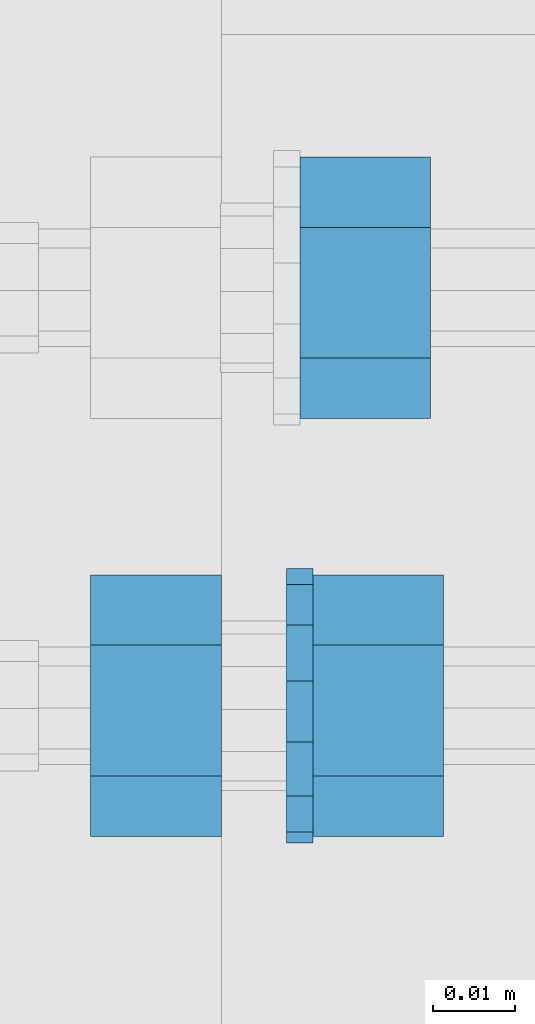
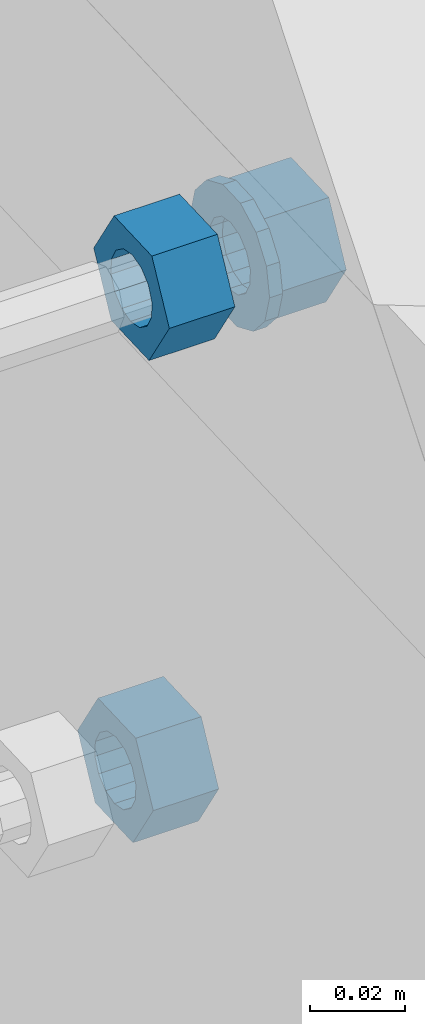
# One storey, part 642 of 975: 4 beams.
"""IFC2X3 building model written with IfcOpenShell, lengths in millimetres."""

from ifc_helpers import new_model, si_unit, frame, origin_with_axes, place, context, subcontext, project, spatial, faceted_brep, material, type_object, element, save


model = new_model("IFC2X3")

# Units and contexts
model_context = context("Model", 3, precision=1e-05, world=origin_with_axes())
body_context = subcontext(model_context, "Body", "Model", "MODEL_VIEW")
ifc_project = project(units=[si_unit("LENGTHUNIT", "METRE", prefix="MILLI"), si_unit("AREAUNIT", "SQUARE_METRE"), si_unit("VOLUMEUNIT", "CUBIC_METRE"), si_unit("MASSUNIT", "GRAM", prefix="KILO"), si_unit("TIMEUNIT", "SECOND"), si_unit("PLANEANGLEUNIT", "RADIAN"), si_unit("SOLIDANGLEUNIT", "STERADIAN"), si_unit("THERMODYNAMICTEMPERATUREUNIT", "DEGREE_CELSIUS"), si_unit("LUMINOUSINTENSITYUNIT", "LUMEN")], contexts=[model_context])

# Site, building, storey
site_placement = place(None, origin_with_axes())
site = spatial("IfcSite", under=ifc_project, at=site_placement, CompositionType="ELEMENT")
building_placement = place(site_placement, origin_with_axes())
building = spatial("IfcBuilding", under=site, at=building_placement, Name="Undefined", CompositionType="ELEMENT")
storey_placement = place(building_placement, origin_with_axes())
storey = spatial("IfcBuildingStorey", under=building, at=storey_placement, Name="Undefined", CompositionType="ELEMENT", Elevation=0.0)

# Beams
ifc_material = material(Name="STEEL/F1554-36")
beam_type_1 = type_object("IfcBeamType", Name="5/8_HEAVY_HEX_NUT", PredefinedType="NOTDEFINED")
beam_1_placement = place(storey_placement, frame((29984.6998520216, 1654.53464107712, 6890.8904456892), z_axis=(3.96407267544419e-09, 0.0430877640020053, -0.999071291046494), x_axis=(-0.999999999999998, 6.90000001668524e-08, 0.0)))
element("IfcBeam", 1, at=beam_1_placement, inside=storey, type_object=beam_type_1, material=ifc_material, Name="HEADED_ANCHOR_BOLT", ObjectType="5/8_HEAVY_HEX_NUT", context=body_context, shape_type="Brep", body=[
    faceted_brep([(-1.09139364212751e-11, -15.8800001144436, -2.72848410531878e-12), (1.45519152283669e-11, -7.94000005722046, -13.7500000000036), (15.8750000000146, -7.94000005722137, -13.7500000000045), (15.8749999999891, -15.8800001144446, -2.72848410531878e-12), (2.91038304567337e-11, 7.94000005722319, -13.7500000000027), (15.8750000000291, 7.94000005722319, -13.7500000000027), (2.18278728425503e-11, 15.8800001144436, 9.09494701772928e-13), (15.8750000000218, 15.8800001144427, 9.09494701772928e-13), (-7.27595761418343e-12, 7.94000005722046, 13.7500000000027), (15.8749999999927, 7.94000005722046, 13.7500000000027), (-2.18278728425503e-11, -7.94000005722228, 13.7500000000009), (15.8749999999782, -7.94000005722319, 13.7500000000009), (-7.27595761418343e-12, 0.0, 8.72999954223724), (0.0, 3.78780484388062, 7.86545780435881), (15.875, 3.78780484387971, 7.86545780435881), (15.8749999999927, -9.09494701772928e-13, 8.72999954223724), (7.27595761418343e-12, 6.82538848405238, 5.44306568481716), (15.8750000000073, 6.82538848405238, 5.44306568481716), (1.09139364212751e-11, 8.51112022706275, 1.94260765157742), (15.8750000000109, 8.51112022706093, 1.94260765157651), (1.45519152283669e-11, 8.51112022706184, -1.94260765157651), (15.8750000000146, 8.51112022706184, -1.94260765157651), (2.18278728425503e-11, 6.8253884840542, -5.44306568481716), (15.8750000000218, 6.82538848405238, -5.44306568481716), (1.81898940354586e-11, 3.78780484388153, -7.86545780435881), (15.8750000000182, 3.78780484388062, -7.86545780435881), (1.81898940354586e-11, 9.09494701772928e-13, -8.72999954223997), (15.8750000000182, 9.09494701772928e-13, -8.72999954223997), (1.09139364212751e-11, -3.78780484387971, -7.86545780436063), (15.8750000000109, -3.78780484388062, -7.86545780436063), (3.63797880709171e-12, -6.82538848405238, -5.44306568481807), (15.8750000000036, -6.82538848405329, -5.44306568481807), (0.0, -8.51112022706184, -1.94260765157833), (15.875, -8.51112022706184, -1.94260765157833), (-7.27595761418343e-12, -8.51112022706184, 1.9426076515756), (15.8749999999927, -8.51112022706275, 1.9426076515756), (-1.09139364212751e-11, -6.82538848405329, 5.44306568481534), (15.8749999999927, -6.8253884840542, 5.44306568481534), (-7.27595761418343e-12, -3.78780484388062, 7.8654578043579), (15.8749999999927, -3.78780484388153, 7.8654578043579)], [[[0, 1, 2, 3]], [[1, 4, 5, 2]], [[4, 6, 7, 5]], [[6, 8, 9, 7]], [[8, 10, 11, 9]], [[10, 0, 3, 11]], [[12, 13, 14, 15]], [[13, 16, 17, 14]], [[16, 18, 19, 17]], [[18, 20, 21, 19]], [[20, 22, 23, 21]], [[22, 24, 25, 23]], [[24, 26, 27, 25]], [[26, 28, 29, 27]], [[28, 30, 31, 29]], [[30, 32, 33, 31]], [[32, 34, 35, 33]], [[34, 36, 37, 35]], [[36, 38, 39, 37]], [[38, 12, 15, 39]], [[5, 7, 9, 11, 3, 2], [17, 19, 21, 23, 25, 27, 29, 31, 33, 35, 37, 39, 15, 14]], [[10, 8, 6, 4, 1, 0], [38, 36, 34, 32, 30, 28, 26, 24, 22, 20, 18, 16, 13, 12]]]),
])
beam_2_placement = place(storey_placement, frame((29959.2998356033, 1603.79133948285, 7053.95547010985), z_axis=(3.96407267544419e-09, 0.0430877640020053, -0.999071291046494), x_axis=(-0.999999999999998, 6.90000001668524e-08, 0.0)))
element("IfcBeam", 2, at=beam_2_placement, inside=storey, type_object=beam_type_1, material=ifc_material, Name="HEADED_ANCHOR_BOLT", ObjectType="5/8_HEAVY_HEX_NUT", context=body_context, shape_type="Brep", body=[
    faceted_brep([(-1.09139364212751e-11, -15.8800001144436, -2.72848410531878e-12), (1.45519152283669e-11, -7.94000005722046, -13.7500000000036), (15.8750000000146, -7.94000005722137, -13.7500000000045), (15.8749999999891, -15.8800001144446, -2.72848410531878e-12), (2.91038304567337e-11, 7.94000005722319, -13.7500000000027), (15.8750000000291, 7.94000005722319, -13.7500000000027), (2.18278728425503e-11, 15.8800001144436, 9.09494701772928e-13), (15.8750000000218, 15.8800001144427, 9.09494701772928e-13), (-7.27595761418343e-12, 7.94000005722046, 13.7500000000027), (15.8749999999927, 7.94000005722046, 13.7500000000027), (-2.18278728425503e-11, -7.94000005722228, 13.7500000000009), (15.8749999999782, -7.94000005722319, 13.7500000000009), (-7.27595761418343e-12, 0.0, 8.72999954223724), (0.0, 3.78780484388062, 7.86545780435881), (15.875, 3.78780484387971, 7.86545780435881), (15.8749999999927, -9.09494701772928e-13, 8.72999954223724), (7.27595761418343e-12, 6.82538848405238, 5.44306568481716), (15.8750000000073, 6.82538848405238, 5.44306568481716), (1.09139364212751e-11, 8.51112022706275, 1.94260765157742), (15.8750000000109, 8.51112022706093, 1.94260765157651), (1.45519152283669e-11, 8.51112022706184, -1.94260765157651), (15.8750000000146, 8.51112022706184, -1.94260765157651), (2.18278728425503e-11, 6.8253884840542, -5.44306568481716), (15.8750000000218, 6.82538848405238, -5.44306568481716), (1.81898940354586e-11, 3.78780484388153, -7.86545780435881), (15.8750000000182, 3.78780484388062, -7.86545780435881), (1.81898940354586e-11, 9.09494701772928e-13, -8.72999954223997), (15.8750000000182, 9.09494701772928e-13, -8.72999954223997), (1.09139364212751e-11, -3.78780484387971, -7.86545780436063), (15.8750000000109, -3.78780484388062, -7.86545780436063), (3.63797880709171e-12, -6.82538848405238, -5.44306568481807), (15.8750000000036, -6.82538848405329, -5.44306568481807), (0.0, -8.51112022706184, -1.94260765157833), (15.875, -8.51112022706184, -1.94260765157833), (-7.27595761418343e-12, -8.51112022706184, 1.9426076515756), (15.8749999999927, -8.51112022706275, 1.9426076515756), (-1.09139364212751e-11, -6.82538848405329, 5.44306568481534), (15.8749999999927, -6.8253884840542, 5.44306568481534), (-7.27595761418343e-12, -3.78780484388062, 7.8654578043579), (15.8749999999927, -3.78780484388153, 7.8654578043579)], [[[0, 1, 2, 3]], [[1, 4, 5, 2]], [[4, 6, 7, 5]], [[6, 8, 9, 7]], [[8, 10, 11, 9]], [[10, 0, 3, 11]], [[12, 13, 14, 15]], [[13, 16, 17, 14]], [[16, 18, 19, 17]], [[18, 20, 21, 19]], [[20, 22, 23, 21]], [[22, 24, 25, 23]], [[24, 26, 27, 25]], [[26, 28, 29, 27]], [[28, 30, 31, 29]], [[30, 32, 33, 31]], [[32, 34, 35, 33]], [[34, 36, 37, 35]], [[36, 38, 39, 37]], [[38, 12, 15, 39]], [[5, 7, 9, 11, 3, 2], [17, 19, 21, 23, 25, 27, 29, 31, 33, 35, 37, 39, 15, 14]], [[10, 8, 6, 4, 1, 0], [38, 36, 34, 32, 30, 28, 26, 24, 22, 20, 18, 16, 13, 12]]]),
])
beam_3_placement = place(storey_placement, frame((29986.2873356035, 1603.7913393359, 7053.95547006284), z_axis=(3.96407267544419e-09, 0.0430877640020053, -0.999071291046494), x_axis=(-0.999999999999998, 6.90000001668524e-08, 0.0)))
element("IfcBeam", 3, at=beam_3_placement, inside=storey, type_object=beam_type_1, material=ifc_material, Name="HEADED_ANCHOR_BOLT", ObjectType="5/8_HEAVY_HEX_NUT", context=body_context, shape_type="Brep", body=[
    faceted_brep([(-1.09139364212751e-11, -15.8800001144436, -2.72848410531878e-12), (1.45519152283669e-11, -7.94000005722046, -13.7500000000036), (15.8750000000146, -7.94000005722137, -13.7500000000045), (15.8749999999891, -15.8800001144446, -2.72848410531878e-12), (2.91038304567337e-11, 7.94000005722319, -13.7500000000027), (15.8750000000291, 7.94000005722319, -13.7500000000027), (2.18278728425503e-11, 15.8800001144436, 9.09494701772928e-13), (15.8750000000218, 15.8800001144427, 9.09494701772928e-13), (-7.27595761418343e-12, 7.94000005722046, 13.7500000000027), (15.8749999999927, 7.94000005722046, 13.7500000000027), (-2.18278728425503e-11, -7.94000005722228, 13.7500000000009), (15.8749999999782, -7.94000005722319, 13.7500000000009), (-7.27595761418343e-12, 0.0, 8.72999954223724), (0.0, 3.78780484388062, 7.86545780435881), (15.875, 3.78780484387971, 7.86545780435881), (15.8749999999927, -9.09494701772928e-13, 8.72999954223724), (7.27595761418343e-12, 6.82538848405238, 5.44306568481716), (15.8750000000073, 6.82538848405238, 5.44306568481716), (1.09139364212751e-11, 8.51112022706275, 1.94260765157742), (15.8750000000109, 8.51112022706093, 1.94260765157651), (1.45519152283669e-11, 8.51112022706184, -1.94260765157651), (15.8750000000146, 8.51112022706184, -1.94260765157651), (2.18278728425503e-11, 6.8253884840542, -5.44306568481716), (15.8750000000218, 6.82538848405238, -5.44306568481716), (1.81898940354586e-11, 3.78780484388153, -7.86545780435881), (15.8750000000182, 3.78780484388062, -7.86545780435881), (1.81898940354586e-11, 9.09494701772928e-13, -8.72999954223997), (15.8750000000182, 9.09494701772928e-13, -8.72999954223997), (1.09139364212751e-11, -3.78780484387971, -7.86545780436063), (15.8750000000109, -3.78780484388062, -7.86545780436063), (3.63797880709171e-12, -6.82538848405238, -5.44306568481807), (15.8750000000036, -6.82538848405329, -5.44306568481807), (0.0, -8.51112022706184, -1.94260765157833), (15.875, -8.51112022706184, -1.94260765157833), (-7.27595761418343e-12, -8.51112022706184, 1.9426076515756), (15.8749999999927, -8.51112022706275, 1.9426076515756), (-1.09139364212751e-11, -6.82538848405329, 5.44306568481534), (15.8749999999927, -6.8253884840542, 5.44306568481534), (-7.27595761418343e-12, -3.78780484388062, 7.8654578043579), (15.8749999999927, -3.78780484388153, 7.8654578043579)], [[[0, 1, 2, 3]], [[1, 4, 5, 2]], [[4, 6, 7, 5]], [[6, 8, 9, 7]], [[8, 10, 11, 9]], [[10, 0, 3, 11]], [[12, 13, 14, 15]], [[13, 16, 17, 14]], [[16, 18, 19, 17]], [[18, 20, 21, 19]], [[20, 22, 23, 21]], [[22, 24, 25, 23]], [[24, 26, 27, 25]], [[26, 28, 29, 27]], [[28, 30, 31, 29]], [[30, 32, 33, 31]], [[32, 34, 35, 33]], [[34, 36, 37, 35]], [[36, 38, 39, 37]], [[38, 12, 15, 39]], [[5, 7, 9, 11, 3, 2], [17, 19, 21, 23, 25, 27, 29, 31, 33, 35, 37, 39, 15, 14]], [[10, 8, 6, 4, 1, 0], [38, 36, 34, 32, 30, 28, 26, 24, 22, 20, 18, 16, 13, 12]]]),
])
beam_type_2 = type_object("IfcBeamType", Name="5/8_WASHER", PredefinedType="NOTDEFINED")
beam_4_placement = place(storey_placement, frame((29970.4123356037, 1603.79133947738, 7053.9554700408), z_axis=(3.96407267544419e-09, 0.0430877640020053, -0.999071291046494), x_axis=(-0.999999999999998, 6.90000001668524e-08, 0.0)))
element("IfcBeam", 4, at=beam_4_placement, inside=storey, type_object=beam_type_2, material=ifc_material, Name="HEADED_ANCHOR_BOLT", ObjectType="5/8_WASHER", context=body_context, shape_type="Brep", body=[
    faceted_brep([(1.09139364212751e-11, -16.670000076293, -2.72848410531878e-12), (2.18278728425503e-11, -15.0191510966704, -7.23284196419536), (3.1750000000211, -15.0191510966711, -7.23284196419627), (3.17500000001019, -16.6700000762937, -1.81898940354586e-12), (2.91038304567337e-11, -10.3935750445523, -13.0331308723944), (3.17500000002838, -10.3935750445526, -13.0331308723953), (2.91038304567337e-11, -3.70942398602756, -16.2520483704566), (3.17500000002838, -3.70942398602779, -16.2520483704566), (2.5465851649642e-11, 3.70942398602961, -16.2520483704557), (3.17500000002474, 3.70942398602961, -16.2520483704566), (1.45519152283669e-11, 10.3935750445542, -13.0331308723935), (3.17500000001382, 10.3935750445537, -13.0331308723944), (0.0, 15.0191510966717, -7.23284196419354), (3.17499999999927, 15.0191510966713, -7.23284196419354), (-7.27595761418343e-12, 16.6700000762933, 0.0), (3.174999999992, 16.6700000762928, -9.09494701772928e-13), (-1.81898940354586e-11, 15.0191510966706, 7.23284196419354), (3.17499999998108, 15.0191510966704, 7.23284196419354), (-2.5465851649642e-11, 10.3935750445519, 13.0331308723926), (3.17499999997381, 10.3935750445517, 13.0331308723926), (-2.5465851649642e-11, 3.70942398602733, 16.2520483704538), (3.17499999997381, 3.7094239860271, 16.2520483704529), (-2.18278728425503e-11, -3.70942398602983, 16.2520483704529), (3.17499999997744, -3.70942398603006, 16.2520483704538), (-1.09139364212751e-11, -10.3935750445542, 13.0331308723908), (3.17499999998836, -10.3935750445544, 13.0331308723908), (0.0, -15.0191510966717, 7.23284196419172), (3.17499999999927, -15.019151096672, 7.23284196419081), (-7.27595761418343e-12, 0.0, 8.72999954223724), (0.0, 3.78780484388062, 7.86545780435881), (3.17499999998472, 3.78780484387903, 7.86545780435699), (3.17499999998836, -9.09494701772928e-13, 8.72999954223542), (7.27595761418343e-12, 6.82538848405238, 5.44306568481716), (3.17499999998836, 6.82538848405102, 5.44306568481534), (1.09139364212751e-11, 8.51112022706275, 1.94260765157742), (3.174999999992, 8.51112022705979, 1.94260765157651), (1.45519152283669e-11, 8.51112022706184, -1.94260765157651), (3.17499999999563, 8.51112022706025, -1.94260765157742), (2.18278728425503e-11, 6.8253884840542, -5.44306568481716), (3.17500000000655, 6.8253884840517, -5.44306568481807), (1.81898940354586e-11, 3.78780484388153, -7.86545780435881), (3.17500000001019, 3.78780484388017, -7.86545780435972), (1.81898940354586e-11, 9.09494701772928e-13, -8.72999954223997), (3.17500000001382, 6.82121026329696e-13, -8.72999954223997), (1.09139364212751e-11, -3.78780484387971, -7.86545780436063), (3.17500000001382, -3.78780484387994, -7.86545780436063), (3.63797880709171e-12, -6.82538848405238, -5.44306568481807), (3.17500000001019, -6.82538848405147, -5.44306568481898), (0.0, -8.51112022706184, -1.94260765157833), (3.17500000001019, -8.5111202270607, -1.94260765157924), (-7.27595761418343e-12, -8.51112022706184, 1.9426076515756), (3.17500000000291, -8.51112022706093, 1.94260765157469), (-1.09139364212751e-11, -6.82538848405329, 5.44306568481534), (3.17499999999563, -6.82538848405238, 5.44306568481534), (-7.27595761418343e-12, -3.78780484388062, 7.8654578043579), (3.174999999992, -3.78780484388085, 7.86545780435699)], [[[0, 1, 2, 3]], [[1, 4, 5, 2]], [[4, 6, 7, 5]], [[6, 8, 9, 7]], [[8, 10, 11, 9]], [[10, 12, 13, 11]], [[12, 14, 15, 13]], [[14, 16, 17, 15]], [[16, 18, 19, 17]], [[18, 20, 21, 19]], [[20, 22, 23, 21]], [[22, 24, 25, 23]], [[24, 26, 27, 25]], [[26, 0, 3, 27]], [[28, 29, 30, 31]], [[29, 32, 33, 30]], [[32, 34, 35, 33]], [[34, 36, 37, 35]], [[36, 38, 39, 37]], [[38, 40, 41, 39]], [[40, 42, 43, 41]], [[42, 44, 45, 43]], [[44, 46, 47, 45]], [[46, 48, 49, 47]], [[48, 50, 51, 49]], [[50, 52, 53, 51]], [[52, 54, 55, 53]], [[54, 28, 31, 55]], [[5, 7, 9, 11, 13, 15, 17, 19, 21, 23, 25, 27, 3, 2], [33, 35, 37, 39, 41, 43, 45, 47, 49, 51, 53, 55, 31, 30]], [[26, 24, 22, 20, 18, 16, 14, 12, 10, 8, 6, 4, 1, 0], [54, 52, 50, 48, 46, 44, 42, 40, 38, 36, 34, 32, 29, 28]]]),
])

save(model, "model.ifc")
